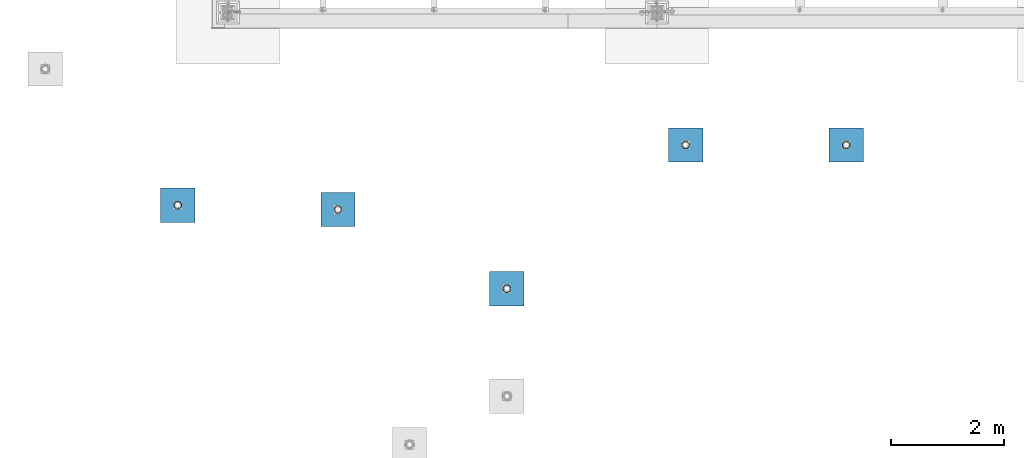
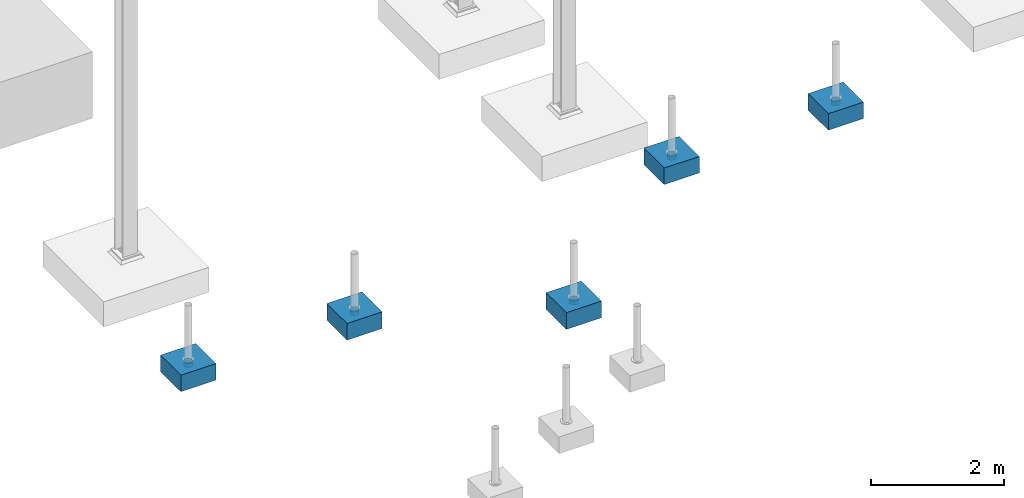
# One storey, part 1536 of 3843: 10 columns, 10 elements without a shape of their own.
"""IFC2X3 building model written with IfcOpenShell, lengths in millimetres."""

from ifc_helpers import new_model, si_unit, frame, origin_with_axes, place, context, subcontext, project, spatial, faceted_brep, material, type_object, element, aggregate, save


model = new_model("IFC2X3")

# Units and contexts
model_context = context("Model", 3, precision=1e-05, world=origin_with_axes())
body_context = subcontext(model_context, "Body", "Model", "MODEL_VIEW")
ifc_project = project(units=[si_unit("LENGTHUNIT", "METRE", prefix="MILLI"), si_unit("AREAUNIT", "SQUARE_METRE"), si_unit("VOLUMEUNIT", "CUBIC_METRE"), si_unit("MASSUNIT", "GRAM", prefix="KILO"), si_unit("TIMEUNIT", "SECOND"), si_unit("PLANEANGLEUNIT", "RADIAN"), si_unit("SOLIDANGLEUNIT", "STERADIAN"), si_unit("THERMODYNAMICTEMPERATUREUNIT", "DEGREE_CELSIUS"), si_unit("LUMINOUSINTENSITYUNIT", "LUMEN")], contexts=[model_context])

# Site, building, storey
site_placement = place(None, origin_with_axes())
site = spatial("IfcSite", under=ifc_project, at=site_placement, CompositionType="ELEMENT")
building_placement = place(site_placement, origin_with_axes())
building = spatial("IfcBuilding", under=site, at=building_placement, Name="Undefined", CompositionType="ELEMENT")
storey_placement = place(building_placement, origin_with_axes())
storey = spatial("IfcBuildingStorey", under=building, at=storey_placement, Name="Undefined", CompositionType="ELEMENT", Elevation=0.0)

# Assembly, column
assembly_1_placement = place(storey_placement, origin_with_axes())
assembly_1 = element("IfcElementAssembly", 1, at=assembly_1_placement, inside=storey, Name="PLATE", AssemblyPlace="NOTDEFINED", PredefinedType="RIGID_FRAME")
ifc_material_1 = material()
column_type_1 = type_object("IfcColumnType", Name="PIPE5SCH40", PredefinedType="NOTDEFINED")
column_1_placement = place(assembly_1_placement, frame((10979.3882215321, 86768.0514528751, 30378.4), z_axis=(-1.0, 0.0, 0.0), x_axis=(0.0, 0.0, 1.0)))
column_1 = element("IfcColumn", 2, at=column_1_placement, type_object=column_type_1, material=ifc_material_1, Name="PIPE_SLEEVE", ObjectType="PIPE5SCH40", context=body_context, shape_type="Brep", body=[
    faceted_brep([(0.0, -64.0587999999998, 0.0), (0.0, -60.9235391660477, 19.7952578392724), (76.2000000000007, -60.9235391660477, 19.7952578392724), (76.2000000000007, -64.0587999999998, 0.0), (0.0, -51.8246578392655, 37.6528179195593), (76.2000000000007, -51.8246578392655, 37.6528179195593), (0.0, -37.6528179195529, 51.8246578392718), (76.2000000000007, -37.6528179195529, 51.8246578392718), (0.0, -19.795257839266, 60.9235391660477), (76.2000000000007, -19.795257839266, 60.9235391660477), (0.0, 0.0, 64.0587999999989), (76.2000000000007, 0.0, 64.0587999999989), (0.0, 19.795257839266, 60.9235391660477), (76.2000000000007, 19.795257839266, 60.9235391660477), (0.0, 37.6528179195529, 51.8246578392718), (76.2000000000007, 37.6528179195529, 51.8246578392718), (0.0, 51.8246578392655, 37.6528179195593), (76.2000000000007, 51.8246578392655, 37.6528179195593), (0.0, 60.9235391660477, 19.7952578392724), (76.2000000000007, 60.9235391660477, 19.7952578392724), (0.0, 64.0587999999998, 0.0), (76.2000000000007, 64.0587999999998, 0.0), (0.0, 60.9235391660477, -19.7952578392724), (76.2000000000007, 60.9235391660477, -19.7952578392724), (0.0, 51.8246578392655, -37.6528179195593), (76.2000000000007, 51.8246578392655, -37.6528179195593), (0.0, 37.6528179195529, -51.8246578392718), (76.2000000000007, 37.6528179195529, -51.8246578392718), (0.0, 19.795257839266, -60.9235391660477), (76.2000000000007, 19.795257839266, -60.9235391660477), (0.0, 0.0, -64.0587999999989), (76.2000000000007, 0.0, -64.0587999999989), (0.0, -19.795257839266, -60.9235391660477), (76.2000000000007, -19.795257839266, -60.9235391660477), (0.0, -37.6528179195529, -51.8246578392718), (76.2000000000007, -37.6528179195529, -51.8246578392718), (0.0, -51.8246578392655, -37.6528179195593), (76.2000000000007, -51.8246578392655, -37.6528179195593), (0.0, -60.9235391660477, -19.7952578392724), (76.2000000000007, -60.9235391660477, -19.7952578392724), (0.0, -70.6120000000001, 0.0), (0.0, -67.1560027286332, -21.8203080068051), (76.2000000000007, -67.1560027286332, -21.8203080068051), (76.2000000000007, -70.6120000000001, 0.0), (0.0, -57.1263080068038, -41.5046922348702), (76.2000000000007, -57.1263080068038, -41.5046922348702), (0.0, -41.5046922348765, -57.126308006802), (76.2000000000007, -41.5046922348765, -57.126308006802), (0.0, -21.8203080068042, -67.1560027286323), (76.2000000000007, -21.8203080068042, -67.1560027286323), (0.0, 0.0, -70.6119999999937), (76.2000000000007, 0.0, -70.6119999999937), (0.0, 21.8203080068042, -67.1560027286323), (76.2000000000007, 21.8203080068042, -67.1560027286323), (0.0, 41.5046922348765, -57.126308006802), (76.2000000000007, 41.5046922348765, -57.126308006802), (0.0, 57.1263080068038, -41.5046922348702), (76.2000000000007, 57.1263080068038, -41.5046922348702), (0.0, 67.1560027286332, -21.8203080068051), (76.2000000000007, 67.1560027286332, -21.8203080068051), (0.0, 70.6120000000001, 0.0), (76.2000000000007, 70.6120000000001, 0.0), (0.0, 67.1560027286332, 21.8203080068051), (76.2000000000007, 67.1560027286332, 21.8203080068051), (0.0, 57.1263080068038, 41.5046922348702), (76.2000000000007, 57.1263080068038, 41.5046922348702), (0.0, 41.5046922348765, 57.126308006802), (76.2000000000007, 41.5046922348765, 57.126308006802), (0.0, 21.8203080068042, 67.1560027286323), (76.2000000000007, 21.8203080068042, 67.1560027286323), (0.0, 0.0, 70.6119999999937), (76.2000000000007, 0.0, 70.6119999999937), (0.0, -21.8203080068042, 67.1560027286323), (76.2000000000007, -21.8203080068042, 67.1560027286323), (0.0, -41.5046922348765, 57.126308006802), (76.2000000000007, -41.5046922348765, 57.126308006802), (0.0, -57.1263080068038, 41.5046922348702), (76.2000000000007, -57.1263080068038, 41.5046922348702), (0.0, -67.1560027286332, 21.8203080068051), (76.2000000000007, -67.1560027286332, 21.8203080068051)], [[[0, 1, 2, 3]], [[1, 4, 5, 2]], [[4, 6, 7, 5]], [[6, 8, 9, 7]], [[8, 10, 11, 9]], [[10, 12, 13, 11]], [[12, 14, 15, 13]], [[14, 16, 17, 15]], [[16, 18, 19, 17]], [[18, 20, 21, 19]], [[20, 22, 23, 21]], [[22, 24, 25, 23]], [[24, 26, 27, 25]], [[26, 28, 29, 27]], [[28, 30, 31, 29]], [[30, 32, 33, 31]], [[32, 34, 35, 33]], [[34, 36, 37, 35]], [[36, 38, 39, 37]], [[38, 0, 3, 39]], [[40, 41, 42, 43]], [[41, 44, 45, 42]], [[44, 46, 47, 45]], [[46, 48, 49, 47]], [[48, 50, 51, 49]], [[50, 52, 53, 51]], [[52, 54, 55, 53]], [[54, 56, 57, 55]], [[56, 58, 59, 57]], [[58, 60, 61, 59]], [[60, 62, 63, 61]], [[62, 64, 65, 63]], [[64, 66, 67, 65]], [[66, 68, 69, 67]], [[68, 70, 71, 69]], [[70, 72, 73, 71]], [[72, 74, 75, 73]], [[74, 76, 77, 75]], [[76, 78, 79, 77]], [[78, 40, 43, 79]], [[45, 47, 49, 51, 53, 55, 57, 59, 61, 63, 65, 67, 69, 71, 73, 75, 77, 79, 43, 42], [5, 7, 9, 11, 13, 15, 17, 19, 21, 23, 25, 27, 29, 31, 33, 35, 37, 39, 3, 2]], [[78, 76, 74, 72, 70, 68, 66, 64, 62, 60, 58, 56, 54, 52, 50, 48, 46, 44, 41, 40], [38, 36, 34, 32, 30, 28, 26, 24, 22, 20, 18, 16, 14, 12, 10, 8, 6, 4, 1, 0]]]),
])
aggregate(assembly_1, [column_1])

assembly_2_placement = place(storey_placement, origin_with_axes())
assembly_2 = element("IfcElementAssembly", 3, at=assembly_2_placement, inside=storey, Name="PLATE", AssemblyPlace="NOTDEFINED", PredefinedType="RIGID_FRAME")
column_2_placement = place(assembly_2_placement, frame((8126.610938, 86767.987501, 30378.4), z_axis=(-1.0, 0.0, 0.0), x_axis=(0.0, 0.0, 1.0)))
column_2 = element("IfcColumn", 4, at=column_2_placement, type_object=column_type_1, material=ifc_material_1, Name="PIPE_SLEEVE", ObjectType="PIPE5SCH40", context=body_context, shape_type="Brep", body=[
    faceted_brep([(0.0, -64.0587999999998, 0.0), (0.0, -60.9235391660477, 19.7952578392724), (76.2000000000007, -60.9235391660477, 19.7952578392724), (76.2000000000007, -64.0587999999998, 0.0), (0.0, -51.8246578392655, 37.6528179195593), (76.2000000000007, -51.8246578392655, 37.6528179195593), (0.0, -37.6528179195529, 51.8246578392718), (76.2000000000007, -37.6528179195529, 51.8246578392718), (0.0, -19.795257839266, 60.9235391660477), (76.2000000000007, -19.795257839266, 60.9235391660477), (0.0, 0.0, 64.0587999999989), (76.2000000000007, 0.0, 64.0587999999989), (0.0, 19.795257839266, 60.9235391660477), (76.2000000000007, 19.795257839266, 60.9235391660477), (0.0, 37.6528179195529, 51.8246578392718), (76.2000000000007, 37.6528179195529, 51.8246578392718), (0.0, 51.8246578392655, 37.6528179195593), (76.2000000000007, 51.8246578392655, 37.6528179195593), (0.0, 60.9235391660477, 19.7952578392724), (76.2000000000007, 60.9235391660477, 19.7952578392724), (0.0, 64.0587999999998, 0.0), (76.2000000000007, 64.0587999999998, 0.0), (0.0, 60.9235391660477, -19.7952578392724), (76.2000000000007, 60.9235391660477, -19.7952578392724), (0.0, 51.8246578392655, -37.6528179195593), (76.2000000000007, 51.8246578392655, -37.6528179195593), (0.0, 37.6528179195529, -51.8246578392718), (76.2000000000007, 37.6528179195529, -51.8246578392718), (0.0, 19.795257839266, -60.9235391660477), (76.2000000000007, 19.795257839266, -60.9235391660477), (0.0, 0.0, -64.0587999999989), (76.2000000000007, 0.0, -64.0587999999989), (0.0, -19.795257839266, -60.9235391660477), (76.2000000000007, -19.795257839266, -60.9235391660477), (0.0, -37.6528179195529, -51.8246578392718), (76.2000000000007, -37.6528179195529, -51.8246578392718), (0.0, -51.8246578392655, -37.6528179195593), (76.2000000000007, -51.8246578392655, -37.6528179195593), (0.0, -60.9235391660477, -19.7952578392724), (76.2000000000007, -60.9235391660477, -19.7952578392724), (0.0, -70.6120000000001, 0.0), (0.0, -67.1560027286332, -21.8203080068051), (76.2000000000007, -67.1560027286332, -21.8203080068051), (76.2000000000007, -70.6120000000001, 0.0), (0.0, -57.1263080068038, -41.5046922348702), (76.2000000000007, -57.1263080068038, -41.5046922348702), (0.0, -41.5046922348765, -57.126308006802), (76.2000000000007, -41.5046922348765, -57.126308006802), (0.0, -21.8203080068042, -67.1560027286323), (76.2000000000007, -21.8203080068042, -67.1560027286323), (0.0, 0.0, -70.6119999999937), (76.2000000000007, 0.0, -70.6119999999937), (0.0, 21.8203080068042, -67.1560027286323), (76.2000000000007, 21.8203080068042, -67.1560027286323), (0.0, 41.5046922348765, -57.126308006802), (76.2000000000007, 41.5046922348765, -57.126308006802), (0.0, 57.1263080068038, -41.5046922348702), (76.2000000000007, 57.1263080068038, -41.5046922348702), (0.0, 67.1560027286332, -21.8203080068051), (76.2000000000007, 67.1560027286332, -21.8203080068051), (0.0, 70.6120000000001, 0.0), (76.2000000000007, 70.6120000000001, 0.0), (0.0, 67.1560027286332, 21.8203080068051), (76.2000000000007, 67.1560027286332, 21.8203080068051), (0.0, 57.1263080068038, 41.5046922348702), (76.2000000000007, 57.1263080068038, 41.5046922348702), (0.0, 41.5046922348765, 57.126308006802), (76.2000000000007, 41.5046922348765, 57.126308006802), (0.0, 21.8203080068042, 67.1560027286323), (76.2000000000007, 21.8203080068042, 67.1560027286323), (0.0, 0.0, 70.6119999999937), (76.2000000000007, 0.0, 70.6119999999937), (0.0, -21.8203080068042, 67.1560027286323), (76.2000000000007, -21.8203080068042, 67.1560027286323), (0.0, -41.5046922348765, 57.126308006802), (76.2000000000007, -41.5046922348765, 57.126308006802), (0.0, -57.1263080068038, 41.5046922348702), (76.2000000000007, -57.1263080068038, 41.5046922348702), (0.0, -67.1560027286332, 21.8203080068051), (76.2000000000007, -67.1560027286332, 21.8203080068051)], [[[0, 1, 2, 3]], [[1, 4, 5, 2]], [[4, 6, 7, 5]], [[6, 8, 9, 7]], [[8, 10, 11, 9]], [[10, 12, 13, 11]], [[12, 14, 15, 13]], [[14, 16, 17, 15]], [[16, 18, 19, 17]], [[18, 20, 21, 19]], [[20, 22, 23, 21]], [[22, 24, 25, 23]], [[24, 26, 27, 25]], [[26, 28, 29, 27]], [[28, 30, 31, 29]], [[30, 32, 33, 31]], [[32, 34, 35, 33]], [[34, 36, 37, 35]], [[36, 38, 39, 37]], [[38, 0, 3, 39]], [[40, 41, 42, 43]], [[41, 44, 45, 42]], [[44, 46, 47, 45]], [[46, 48, 49, 47]], [[48, 50, 51, 49]], [[50, 52, 53, 51]], [[52, 54, 55, 53]], [[54, 56, 57, 55]], [[56, 58, 59, 57]], [[58, 60, 61, 59]], [[60, 62, 63, 61]], [[62, 64, 65, 63]], [[64, 66, 67, 65]], [[66, 68, 69, 67]], [[68, 70, 71, 69]], [[70, 72, 73, 71]], [[72, 74, 75, 73]], [[74, 76, 77, 75]], [[76, 78, 79, 77]], [[78, 40, 43, 79]], [[45, 47, 49, 51, 53, 55, 57, 59, 61, 63, 65, 67, 69, 71, 73, 75, 77, 79, 43, 42], [5, 7, 9, 11, 13, 15, 17, 19, 21, 23, 25, 27, 29, 31, 33, 35, 37, 39, 3, 2]], [[78, 76, 74, 72, 70, 68, 66, 64, 62, 60, 58, 56, 54, 52, 50, 48, 46, 44, 41, 40], [38, 36, 34, 32, 30, 28, 26, 24, 22, 20, 18, 16, 14, 12, 10, 8, 6, 4, 1, 0]]]),
])
aggregate(assembly_2, [column_2])

assembly_3_placement = place(storey_placement, origin_with_axes())
assembly_3 = element("IfcElementAssembly", 5, at=assembly_3_placement, inside=storey, Name="PLATE", AssemblyPlace="NOTDEFINED", PredefinedType="RIGID_FRAME")
column_3_placement = place(assembly_3_placement, frame((4953.79375, 84215.684376, 30378.4), z_axis=(-1.0, 0.0, 0.0), x_axis=(0.0, 0.0, 1.0)))
column_3 = element("IfcColumn", 6, at=column_3_placement, type_object=column_type_1, material=ifc_material_1, Name="PIPE_SLEEVE", ObjectType="PIPE5SCH40", context=body_context, shape_type="Brep", body=[
    faceted_brep([(0.0, -64.0587999999998, 0.0), (0.0, -60.9235391660477, 19.7952578392724), (76.2000000000007, -60.9235391660477, 19.7952578392724), (76.2000000000007, -64.0587999999998, 0.0), (0.0, -51.8246578392655, 37.6528179195593), (76.2000000000007, -51.8246578392655, 37.6528179195593), (0.0, -37.6528179195529, 51.8246578392718), (76.2000000000007, -37.6528179195529, 51.8246578392718), (0.0, -19.795257839266, 60.9235391660477), (76.2000000000007, -19.795257839266, 60.9235391660477), (0.0, 0.0, 64.0587999999989), (76.2000000000007, 0.0, 64.0587999999989), (0.0, 19.795257839266, 60.9235391660477), (76.2000000000007, 19.795257839266, 60.9235391660477), (0.0, 37.6528179195529, 51.8246578392718), (76.2000000000007, 37.6528179195529, 51.8246578392718), (0.0, 51.8246578392655, 37.6528179195593), (76.2000000000007, 51.8246578392655, 37.6528179195593), (0.0, 60.9235391660477, 19.7952578392724), (76.2000000000007, 60.9235391660477, 19.7952578392724), (0.0, 64.0587999999998, 0.0), (76.2000000000007, 64.0587999999998, 0.0), (0.0, 60.9235391660477, -19.7952578392724), (76.2000000000007, 60.9235391660477, -19.7952578392724), (0.0, 51.8246578392655, -37.6528179195593), (76.2000000000007, 51.8246578392655, -37.6528179195593), (0.0, 37.6528179195529, -51.8246578392718), (76.2000000000007, 37.6528179195529, -51.8246578392718), (0.0, 19.795257839266, -60.9235391660477), (76.2000000000007, 19.795257839266, -60.9235391660477), (0.0, 0.0, -64.0587999999989), (76.2000000000007, 0.0, -64.0587999999989), (0.0, -19.795257839266, -60.9235391660477), (76.2000000000007, -19.795257839266, -60.9235391660477), (0.0, -37.6528179195529, -51.8246578392718), (76.2000000000007, -37.6528179195529, -51.8246578392718), (0.0, -51.8246578392655, -37.6528179195593), (76.2000000000007, -51.8246578392655, -37.6528179195593), (0.0, -60.9235391660477, -19.7952578392724), (76.2000000000007, -60.9235391660477, -19.7952578392724), (0.0, -70.6120000000001, 0.0), (0.0, -67.1560027286332, -21.8203080068051), (76.2000000000007, -67.1560027286332, -21.8203080068051), (76.2000000000007, -70.6120000000001, 0.0), (0.0, -57.1263080068038, -41.5046922348702), (76.2000000000007, -57.1263080068038, -41.5046922348702), (0.0, -41.5046922348765, -57.126308006802), (76.2000000000007, -41.5046922348765, -57.126308006802), (0.0, -21.8203080068042, -67.1560027286323), (76.2000000000007, -21.8203080068042, -67.1560027286323), (0.0, 0.0, -70.6119999999937), (76.2000000000007, 0.0, -70.6119999999937), (0.0, 21.8203080068042, -67.1560027286323), (76.2000000000007, 21.8203080068042, -67.1560027286323), (0.0, 41.5046922348765, -57.126308006802), (76.2000000000007, 41.5046922348765, -57.126308006802), (0.0, 57.1263080068038, -41.5046922348702), (76.2000000000007, 57.1263080068038, -41.5046922348702), (0.0, 67.1560027286332, -21.8203080068051), (76.2000000000007, 67.1560027286332, -21.8203080068051), (0.0, 70.6120000000001, 0.0), (76.2000000000007, 70.6120000000001, 0.0), (0.0, 67.1560027286332, 21.8203080068051), (76.2000000000007, 67.1560027286332, 21.8203080068051), (0.0, 57.1263080068038, 41.5046922348702), (76.2000000000007, 57.1263080068038, 41.5046922348702), (0.0, 41.5046922348765, 57.126308006802), (76.2000000000007, 41.5046922348765, 57.126308006802), (0.0, 21.8203080068042, 67.1560027286323), (76.2000000000007, 21.8203080068042, 67.1560027286323), (0.0, 0.0, 70.6119999999937), (76.2000000000007, 0.0, 70.6119999999937), (0.0, -21.8203080068042, 67.1560027286323), (76.2000000000007, -21.8203080068042, 67.1560027286323), (0.0, -41.5046922348765, 57.126308006802), (76.2000000000007, -41.5046922348765, 57.126308006802), (0.0, -57.1263080068038, 41.5046922348702), (76.2000000000007, -57.1263080068038, 41.5046922348702), (0.0, -67.1560027286332, 21.8203080068051), (76.2000000000007, -67.1560027286332, 21.8203080068051)], [[[0, 1, 2, 3]], [[1, 4, 5, 2]], [[4, 6, 7, 5]], [[6, 8, 9, 7]], [[8, 10, 11, 9]], [[10, 12, 13, 11]], [[12, 14, 15, 13]], [[14, 16, 17, 15]], [[16, 18, 19, 17]], [[18, 20, 21, 19]], [[20, 22, 23, 21]], [[22, 24, 25, 23]], [[24, 26, 27, 25]], [[26, 28, 29, 27]], [[28, 30, 31, 29]], [[30, 32, 33, 31]], [[32, 34, 35, 33]], [[34, 36, 37, 35]], [[36, 38, 39, 37]], [[38, 0, 3, 39]], [[40, 41, 42, 43]], [[41, 44, 45, 42]], [[44, 46, 47, 45]], [[46, 48, 49, 47]], [[48, 50, 51, 49]], [[50, 52, 53, 51]], [[52, 54, 55, 53]], [[54, 56, 57, 55]], [[56, 58, 59, 57]], [[58, 60, 61, 59]], [[60, 62, 63, 61]], [[62, 64, 65, 63]], [[64, 66, 67, 65]], [[66, 68, 69, 67]], [[68, 70, 71, 69]], [[70, 72, 73, 71]], [[72, 74, 75, 73]], [[74, 76, 77, 75]], [[76, 78, 79, 77]], [[78, 40, 43, 79]], [[45, 47, 49, 51, 53, 55, 57, 59, 61, 63, 65, 67, 69, 71, 73, 75, 77, 79, 43, 42], [5, 7, 9, 11, 13, 15, 17, 19, 21, 23, 25, 27, 29, 31, 33, 35, 37, 39, 3, 2]], [[78, 76, 74, 72, 70, 68, 66, 64, 62, 60, 58, 56, 54, 52, 50, 48, 46, 44, 41, 40], [38, 36, 34, 32, 30, 28, 26, 24, 22, 20, 18, 16, 14, 12, 10, 8, 6, 4, 1, 0]]]),
])
aggregate(assembly_3, [column_3])

assembly_4_placement = place(storey_placement, origin_with_axes())
assembly_4 = element("IfcElementAssembly", 7, at=assembly_4_placement, inside=storey, Name="PLATE", AssemblyPlace="NOTDEFINED", PredefinedType="RIGID_FRAME")
column_4_placement = place(assembly_4_placement, frame((1954.609375, 85621.018751, 30378.4), z_axis=(-1.0, 0.0, 0.0), x_axis=(0.0, 0.0, 1.0)))
column_4 = element("IfcColumn", 8, at=column_4_placement, type_object=column_type_1, material=ifc_material_1, Name="PIPE_SLEEVE", ObjectType="PIPE5SCH40", context=body_context, shape_type="Brep", body=[
    faceted_brep([(0.0, -64.0587999999998, 0.0), (0.0, -60.9235391660477, 19.7952578392724), (76.2000000000007, -60.9235391660477, 19.7952578392724), (76.2000000000007, -64.0587999999998, 0.0), (0.0, -51.8246578392655, 37.6528179195593), (76.2000000000007, -51.8246578392655, 37.6528179195593), (0.0, -37.6528179195529, 51.8246578392718), (76.2000000000007, -37.6528179195529, 51.8246578392718), (0.0, -19.795257839266, 60.9235391660477), (76.2000000000007, -19.795257839266, 60.9235391660477), (0.0, 0.0, 64.0587999999989), (76.2000000000007, 0.0, 64.0587999999989), (0.0, 19.795257839266, 60.9235391660477), (76.2000000000007, 19.795257839266, 60.9235391660477), (0.0, 37.6528179195529, 51.8246578392718), (76.2000000000007, 37.6528179195529, 51.8246578392718), (0.0, 51.8246578392655, 37.6528179195593), (76.2000000000007, 51.8246578392655, 37.6528179195593), (0.0, 60.9235391660477, 19.7952578392724), (76.2000000000007, 60.9235391660477, 19.7952578392724), (0.0, 64.0587999999998, 0.0), (76.2000000000007, 64.0587999999998, 0.0), (0.0, 60.9235391660477, -19.7952578392724), (76.2000000000007, 60.9235391660477, -19.7952578392724), (0.0, 51.8246578392655, -37.6528179195593), (76.2000000000007, 51.8246578392655, -37.6528179195593), (0.0, 37.6528179195529, -51.8246578392718), (76.2000000000007, 37.6528179195529, -51.8246578392718), (0.0, 19.795257839266, -60.9235391660477), (76.2000000000007, 19.795257839266, -60.9235391660477), (0.0, 0.0, -64.0587999999989), (76.2000000000007, 0.0, -64.0587999999989), (0.0, -19.795257839266, -60.9235391660477), (76.2000000000007, -19.795257839266, -60.9235391660477), (0.0, -37.6528179195529, -51.8246578392718), (76.2000000000007, -37.6528179195529, -51.8246578392718), (0.0, -51.8246578392655, -37.6528179195593), (76.2000000000007, -51.8246578392655, -37.6528179195593), (0.0, -60.9235391660477, -19.7952578392724), (76.2000000000007, -60.9235391660477, -19.7952578392724), (0.0, -70.6120000000001, 0.0), (0.0, -67.1560027286332, -21.8203080068051), (76.2000000000007, -67.1560027286332, -21.8203080068051), (76.2000000000007, -70.6120000000001, 0.0), (0.0, -57.1263080068038, -41.5046922348702), (76.2000000000007, -57.1263080068038, -41.5046922348702), (0.0, -41.5046922348765, -57.126308006802), (76.2000000000007, -41.5046922348765, -57.126308006802), (0.0, -21.8203080068042, -67.1560027286323), (76.2000000000007, -21.8203080068042, -67.1560027286323), (0.0, 0.0, -70.6119999999937), (76.2000000000007, 0.0, -70.6119999999937), (0.0, 21.8203080068042, -67.1560027286323), (76.2000000000007, 21.8203080068042, -67.1560027286323), (0.0, 41.5046922348765, -57.126308006802), (76.2000000000007, 41.5046922348765, -57.126308006802), (0.0, 57.1263080068038, -41.5046922348702), (76.2000000000007, 57.1263080068038, -41.5046922348702), (0.0, 67.1560027286332, -21.8203080068051), (76.2000000000007, 67.1560027286332, -21.8203080068051), (0.0, 70.6120000000001, 0.0), (76.2000000000007, 70.6120000000001, 0.0), (0.0, 67.1560027286332, 21.8203080068051), (76.2000000000007, 67.1560027286332, 21.8203080068051), (0.0, 57.1263080068038, 41.5046922348702), (76.2000000000007, 57.1263080068038, 41.5046922348702), (0.0, 41.5046922348765, 57.126308006802), (76.2000000000007, 41.5046922348765, 57.126308006802), (0.0, 21.8203080068042, 67.1560027286323), (76.2000000000007, 21.8203080068042, 67.1560027286323), (0.0, 0.0, 70.6119999999937), (76.2000000000007, 0.0, 70.6119999999937), (0.0, -21.8203080068042, 67.1560027286323), (76.2000000000007, -21.8203080068042, 67.1560027286323), (0.0, -41.5046922348765, 57.126308006802), (76.2000000000007, -41.5046922348765, 57.126308006802), (0.0, -57.1263080068038, 41.5046922348702), (76.2000000000007, -57.1263080068038, 41.5046922348702), (0.0, -67.1560027286332, 21.8203080068051), (76.2000000000007, -67.1560027286332, 21.8203080068051)], [[[0, 1, 2, 3]], [[1, 4, 5, 2]], [[4, 6, 7, 5]], [[6, 8, 9, 7]], [[8, 10, 11, 9]], [[10, 12, 13, 11]], [[12, 14, 15, 13]], [[14, 16, 17, 15]], [[16, 18, 19, 17]], [[18, 20, 21, 19]], [[20, 22, 23, 21]], [[22, 24, 25, 23]], [[24, 26, 27, 25]], [[26, 28, 29, 27]], [[28, 30, 31, 29]], [[30, 32, 33, 31]], [[32, 34, 35, 33]], [[34, 36, 37, 35]], [[36, 38, 39, 37]], [[38, 0, 3, 39]], [[40, 41, 42, 43]], [[41, 44, 45, 42]], [[44, 46, 47, 45]], [[46, 48, 49, 47]], [[48, 50, 51, 49]], [[50, 52, 53, 51]], [[52, 54, 55, 53]], [[54, 56, 57, 55]], [[56, 58, 59, 57]], [[58, 60, 61, 59]], [[60, 62, 63, 61]], [[62, 64, 65, 63]], [[64, 66, 67, 65]], [[66, 68, 69, 67]], [[68, 70, 71, 69]], [[70, 72, 73, 71]], [[72, 74, 75, 73]], [[74, 76, 77, 75]], [[76, 78, 79, 77]], [[78, 40, 43, 79]], [[45, 47, 49, 51, 53, 55, 57, 59, 61, 63, 65, 67, 69, 71, 73, 75, 77, 79, 43, 42], [5, 7, 9, 11, 13, 15, 17, 19, 21, 23, 25, 27, 29, 31, 33, 35, 37, 39, 3, 2]], [[78, 76, 74, 72, 70, 68, 66, 64, 62, 60, 58, 56, 54, 52, 50, 48, 46, 44, 41, 40], [38, 36, 34, 32, 30, 28, 26, 24, 22, 20, 18, 16, 14, 12, 10, 8, 6, 4, 1, 0]]]),
])
aggregate(assembly_4, [column_4])

assembly_5_placement = place(storey_placement, origin_with_axes())
assembly_5 = element("IfcElementAssembly", 9, at=assembly_5_placement, inside=storey, Name="PLATE", AssemblyPlace="NOTDEFINED", PredefinedType="RIGID_FRAME")
column_5_placement = place(assembly_5_placement, frame((-889.992187999998, 85698.210939, 30378.4), z_axis=(-1.0, 0.0, 0.0), x_axis=(0.0, 0.0, 1.0)))
column_5 = element("IfcColumn", 10, at=column_5_placement, type_object=column_type_1, material=ifc_material_1, Name="PIPE_SLEEVE", ObjectType="PIPE5SCH40", context=body_context, shape_type="Brep", body=[
    faceted_brep([(0.0, -64.0587999999998, 0.0), (0.0, -60.9235391660477, 19.7952578392724), (76.2000000000007, -60.9235391660477, 19.7952578392724), (76.2000000000007, -64.0587999999998, 0.0), (0.0, -51.8246578392655, 37.6528179195593), (76.2000000000007, -51.8246578392655, 37.6528179195593), (0.0, -37.6528179195529, 51.8246578392718), (76.2000000000007, -37.6528179195529, 51.8246578392718), (0.0, -19.795257839266, 60.9235391660477), (76.2000000000007, -19.795257839266, 60.9235391660477), (0.0, 0.0, 64.0587999999989), (76.2000000000007, 0.0, 64.0587999999989), (0.0, 19.795257839266, 60.9235391660477), (76.2000000000007, 19.795257839266, 60.9235391660477), (0.0, 37.6528179195529, 51.8246578392718), (76.2000000000007, 37.6528179195529, 51.8246578392718), (0.0, 51.8246578392655, 37.6528179195593), (76.2000000000007, 51.8246578392655, 37.6528179195593), (0.0, 60.9235391660477, 19.7952578392724), (76.2000000000007, 60.9235391660477, 19.7952578392724), (0.0, 64.0587999999998, 0.0), (76.2000000000007, 64.0587999999998, 0.0), (0.0, 60.9235391660477, -19.7952578392724), (76.2000000000007, 60.9235391660477, -19.7952578392724), (0.0, 51.8246578392655, -37.6528179195593), (76.2000000000007, 51.8246578392655, -37.6528179195593), (0.0, 37.6528179195529, -51.8246578392718), (76.2000000000007, 37.6528179195529, -51.8246578392718), (0.0, 19.795257839266, -60.9235391660477), (76.2000000000007, 19.795257839266, -60.9235391660477), (0.0, 0.0, -64.0587999999989), (76.2000000000007, 0.0, -64.0587999999989), (0.0, -19.795257839266, -60.9235391660477), (76.2000000000007, -19.795257839266, -60.9235391660477), (0.0, -37.6528179195529, -51.8246578392718), (76.2000000000007, -37.6528179195529, -51.8246578392718), (0.0, -51.8246578392655, -37.6528179195593), (76.2000000000007, -51.8246578392655, -37.6528179195593), (0.0, -60.9235391660477, -19.7952578392724), (76.2000000000007, -60.9235391660477, -19.7952578392724), (0.0, -70.6120000000001, 0.0), (0.0, -67.1560027286332, -21.8203080068051), (76.2000000000007, -67.1560027286332, -21.8203080068051), (76.2000000000007, -70.6120000000001, 0.0), (0.0, -57.1263080068038, -41.5046922348702), (76.2000000000007, -57.1263080068038, -41.5046922348702), (0.0, -41.5046922348765, -57.126308006802), (76.2000000000007, -41.5046922348765, -57.126308006802), (0.0, -21.8203080068042, -67.1560027286323), (76.2000000000007, -21.8203080068042, -67.1560027286323), (0.0, 0.0, -70.6119999999937), (76.2000000000007, 0.0, -70.6119999999937), (0.0, 21.8203080068042, -67.1560027286323), (76.2000000000007, 21.8203080068042, -67.1560027286323), (0.0, 41.5046922348765, -57.126308006802), (76.2000000000007, 41.5046922348765, -57.126308006802), (0.0, 57.1263080068038, -41.5046922348702), (76.2000000000007, 57.1263080068038, -41.5046922348702), (0.0, 67.1560027286332, -21.8203080068051), (76.2000000000007, 67.1560027286332, -21.8203080068051), (0.0, 70.6120000000001, 0.0), (76.2000000000007, 70.6120000000001, 0.0), (0.0, 67.1560027286332, 21.8203080068051), (76.2000000000007, 67.1560027286332, 21.8203080068051), (0.0, 57.1263080068038, 41.5046922348702), (76.2000000000007, 57.1263080068038, 41.5046922348702), (0.0, 41.5046922348765, 57.126308006802), (76.2000000000007, 41.5046922348765, 57.126308006802), (0.0, 21.8203080068042, 67.1560027286323), (76.2000000000007, 21.8203080068042, 67.1560027286323), (0.0, 0.0, 70.6119999999937), (76.2000000000007, 0.0, 70.6119999999937), (0.0, -21.8203080068042, 67.1560027286323), (76.2000000000007, -21.8203080068042, 67.1560027286323), (0.0, -41.5046922348765, 57.126308006802), (76.2000000000007, -41.5046922348765, 57.126308006802), (0.0, -57.1263080068038, 41.5046922348702), (76.2000000000007, -57.1263080068038, 41.5046922348702), (0.0, -67.1560027286332, 21.8203080068051), (76.2000000000007, -67.1560027286332, 21.8203080068051)], [[[0, 1, 2, 3]], [[1, 4, 5, 2]], [[4, 6, 7, 5]], [[6, 8, 9, 7]], [[8, 10, 11, 9]], [[10, 12, 13, 11]], [[12, 14, 15, 13]], [[14, 16, 17, 15]], [[16, 18, 19, 17]], [[18, 20, 21, 19]], [[20, 22, 23, 21]], [[22, 24, 25, 23]], [[24, 26, 27, 25]], [[26, 28, 29, 27]], [[28, 30, 31, 29]], [[30, 32, 33, 31]], [[32, 34, 35, 33]], [[34, 36, 37, 35]], [[36, 38, 39, 37]], [[38, 0, 3, 39]], [[40, 41, 42, 43]], [[41, 44, 45, 42]], [[44, 46, 47, 45]], [[46, 48, 49, 47]], [[48, 50, 51, 49]], [[50, 52, 53, 51]], [[52, 54, 55, 53]], [[54, 56, 57, 55]], [[56, 58, 59, 57]], [[58, 60, 61, 59]], [[60, 62, 63, 61]], [[62, 64, 65, 63]], [[64, 66, 67, 65]], [[66, 68, 69, 67]], [[68, 70, 71, 69]], [[70, 72, 73, 71]], [[72, 74, 75, 73]], [[74, 76, 77, 75]], [[76, 78, 79, 77]], [[78, 40, 43, 79]], [[45, 47, 49, 51, 53, 55, 57, 59, 61, 63, 65, 67, 69, 71, 73, 75, 77, 79, 43, 42], [5, 7, 9, 11, 13, 15, 17, 19, 21, 23, 25, 27, 29, 31, 33, 35, 37, 39, 3, 2]], [[78, 76, 74, 72, 70, 68, 66, 64, 62, 60, 58, 56, 54, 52, 50, 48, 46, 44, 41, 40], [38, 36, 34, 32, 30, 28, 26, 24, 22, 20, 18, 16, 14, 12, 10, 8, 6, 4, 1, 0]]]),
])
aggregate(assembly_5, [column_5])

assembly_6_placement = place(storey_placement, origin_with_axes())
assembly_6 = element("IfcElementAssembly", 11, at=assembly_6_placement, inside=storey, Name="CONC_COL.", AssemblyPlace="NOTDEFINED", PredefinedType="REINFORCEMENT_UNIT")
ifc_material_2 = material(Name="CONCRETE/3000")
column_type_2 = type_object("IfcColumnType", PredefinedType="NOTDEFINED")
column_6_placement = place(assembly_6_placement, frame((10979.3882215321, 86768.0514528751, 30175.2), z_axis=(-1.0, 0.0, 0.0), x_axis=(0.0, 0.0, 1.0)))
column_6 = element("IfcColumn", 12, at=column_6_placement, type_object=column_type_2, material=ifc_material_2, Name="CONC_COL.", context=body_context, shape_type="Brep", body=[
    faceted_brep([(0.0, 304.8, -304.800000000003), (0.0, 304.8, 304.800000000003), (304.799999999999, 304.8, 304.800000000003), (304.799999999999, 304.8, -304.800000000003), (0.0, -304.8, 304.800000000003), (304.799999999999, -304.8, 304.800000000003), (0.0, -304.8, -304.800000000003), (304.799999999999, -304.8, -304.800000000003)], [[[0, 1, 2, 3]], [[1, 4, 5, 2]], [[4, 6, 7, 5]], [[6, 0, 3, 7]], [[5, 7, 3, 2]], [[6, 4, 1, 0]]]),
])
aggregate(assembly_6, [column_6])

assembly_7_placement = place(storey_placement, origin_with_axes())
assembly_7 = element("IfcElementAssembly", 13, at=assembly_7_placement, inside=storey, Name="CONC_COL.", AssemblyPlace="NOTDEFINED", PredefinedType="REINFORCEMENT_UNIT")
column_7_placement = place(assembly_7_placement, frame((8126.610938, 86767.987501, 30175.2), z_axis=(-1.0, 0.0, 0.0), x_axis=(0.0, 0.0, 1.0)))
column_7 = element("IfcColumn", 14, at=column_7_placement, type_object=column_type_2, material=ifc_material_2, Name="CONC_COL.", context=body_context, shape_type="Brep", body=[
    faceted_brep([(0.0, 304.8, -304.800000000003), (0.0, 304.8, 304.800000000003), (304.799999999999, 304.8, 304.800000000003), (304.799999999999, 304.8, -304.800000000003), (0.0, -304.8, 304.800000000003), (304.799999999999, -304.8, 304.800000000003), (0.0, -304.8, -304.800000000003), (304.799999999999, -304.8, -304.800000000003)], [[[0, 1, 2, 3]], [[1, 4, 5, 2]], [[4, 6, 7, 5]], [[6, 0, 3, 7]], [[5, 7, 3, 2]], [[6, 4, 1, 0]]]),
])
aggregate(assembly_7, [column_7])

assembly_8_placement = place(storey_placement, origin_with_axes())
assembly_8 = element("IfcElementAssembly", 15, at=assembly_8_placement, inside=storey, Name="CONC_COL.", AssemblyPlace="NOTDEFINED", PredefinedType="REINFORCEMENT_UNIT")
column_8_placement = place(assembly_8_placement, frame((4953.79375, 84215.684376, 30175.2), z_axis=(-1.0, 0.0, 0.0), x_axis=(0.0, 0.0, 1.0)))
column_8 = element("IfcColumn", 16, at=column_8_placement, type_object=column_type_2, material=ifc_material_2, Name="CONC_COL.", context=body_context, shape_type="Brep", body=[
    faceted_brep([(0.0, 304.8, -304.800000000003), (0.0, 304.8, 304.800000000003), (304.799999999999, 304.8, 304.800000000003), (304.799999999999, 304.8, -304.800000000003), (0.0, -304.8, 304.800000000003), (304.799999999999, -304.8, 304.800000000003), (0.0, -304.8, -304.800000000003), (304.799999999999, -304.8, -304.800000000003)], [[[0, 1, 2, 3]], [[1, 4, 5, 2]], [[4, 6, 7, 5]], [[6, 0, 3, 7]], [[5, 7, 3, 2]], [[6, 4, 1, 0]]]),
])
aggregate(assembly_8, [column_8])

assembly_9_placement = place(storey_placement, origin_with_axes())
assembly_9 = element("IfcElementAssembly", 17, at=assembly_9_placement, inside=storey, Name="CONC_COL.", AssemblyPlace="NOTDEFINED", PredefinedType="REINFORCEMENT_UNIT")
column_9_placement = place(assembly_9_placement, frame((1954.609375, 85621.018751, 30175.2), z_axis=(-1.0, 0.0, 0.0), x_axis=(0.0, 0.0, 1.0)))
column_9 = element("IfcColumn", 18, at=column_9_placement, type_object=column_type_2, material=ifc_material_2, Name="CONC_COL.", context=body_context, shape_type="Brep", body=[
    faceted_brep([(0.0, 304.8, -304.800000000003), (0.0, 304.8, 304.800000000003), (304.799999999999, 304.8, 304.800000000003), (304.799999999999, 304.8, -304.800000000003), (0.0, -304.8, 304.800000000003), (304.799999999999, -304.8, 304.800000000003), (0.0, -304.8, -304.800000000003), (304.799999999999, -304.8, -304.800000000003)], [[[0, 1, 2, 3]], [[1, 4, 5, 2]], [[4, 6, 7, 5]], [[6, 0, 3, 7]], [[5, 7, 3, 2]], [[6, 4, 1, 0]]]),
])
aggregate(assembly_9, [column_9])

assembly_10_placement = place(storey_placement, origin_with_axes())
assembly_10 = element("IfcElementAssembly", 19, at=assembly_10_placement, inside=storey, Name="CONC_COL.", AssemblyPlace="NOTDEFINED", PredefinedType="REINFORCEMENT_UNIT")
column_10_placement = place(assembly_10_placement, frame((-889.992187999998, 85698.210939, 30175.2), z_axis=(-1.0, 0.0, 0.0), x_axis=(0.0, 0.0, 1.0)))
column_10 = element("IfcColumn", 20, at=column_10_placement, type_object=column_type_2, material=ifc_material_2, Name="CONC_COL.", context=body_context, shape_type="Brep", body=[
    faceted_brep([(0.0, 304.8, -304.800000000003), (0.0, 304.8, 304.800000000003), (304.799999999999, 304.8, 304.800000000003), (304.799999999999, 304.8, -304.800000000003), (0.0, -304.8, 304.800000000003), (304.799999999999, -304.8, 304.800000000003), (0.0, -304.8, -304.800000000003), (304.799999999999, -304.8, -304.800000000003)], [[[0, 1, 2, 3]], [[1, 4, 5, 2]], [[4, 6, 7, 5]], [[6, 0, 3, 7]], [[5, 7, 3, 2]], [[6, 4, 1, 0]]]),
])
aggregate(assembly_10, [column_10])

save(model, "model.ifc")
